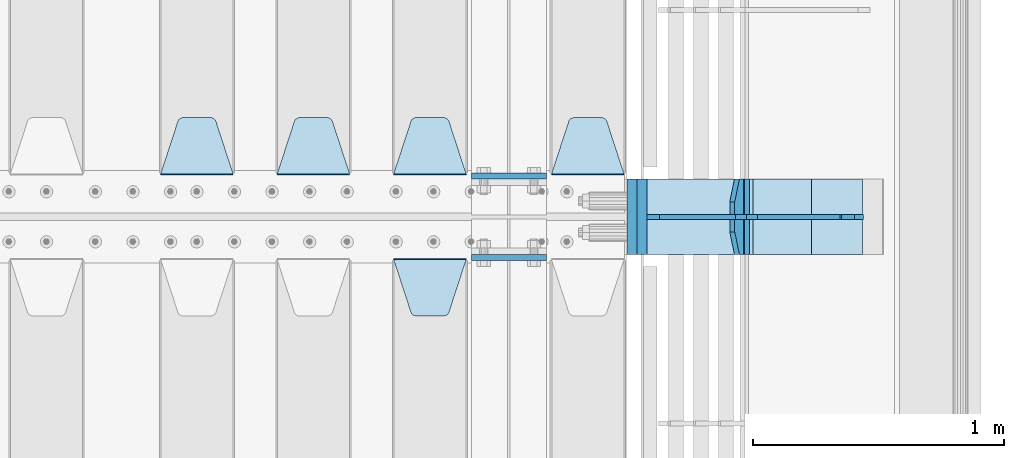
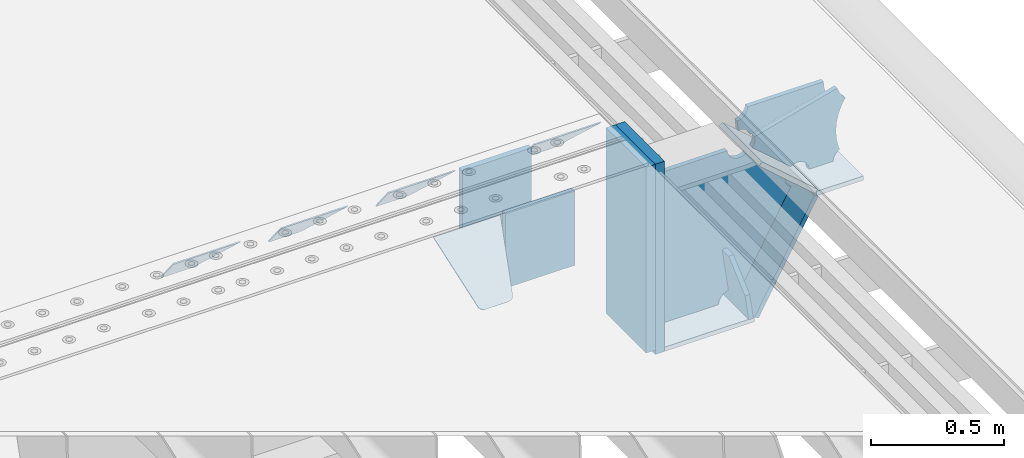
# One storey, part 238 of 257: 17 plates.
"""IFC2X3 building model written with IfcOpenShell, lengths in millimetres."""

from ifc_helpers import new_model, si_unit, frame, origin_with_axes, place, context, subcontext, project, spatial, faceted_brep, material, type_object, element, save


model = new_model("IFC2X3")

# Units and contexts
model_context = context("Model", 3, precision=1e-05, world=origin_with_axes())
body_context = subcontext(model_context, "Body", "Model", "MODEL_VIEW")
ifc_project = project(units=[si_unit("LENGTHUNIT", "METRE", prefix="MILLI"), si_unit("AREAUNIT", "SQUARE_METRE"), si_unit("VOLUMEUNIT", "CUBIC_METRE"), si_unit("MASSUNIT", "GRAM", prefix="KILO"), si_unit("TIMEUNIT", "SECOND"), si_unit("PLANEANGLEUNIT", "RADIAN"), si_unit("SOLIDANGLEUNIT", "STERADIAN"), si_unit("THERMODYNAMICTEMPERATUREUNIT", "DEGREE_CELSIUS"), si_unit("LUMINOUSINTENSITYUNIT", "LUMEN")], contexts=[model_context])

# Site, building, storey
site_placement = place(None, origin_with_axes())
site = spatial("IfcSite", under=ifc_project, at=site_placement, CompositionType="ELEMENT")
building_placement = place(site_placement, origin_with_axes())
building = spatial("IfcBuilding", under=site, at=building_placement, Name="Standard", CompositionType="ELEMENT")
storey_placement = place(building_placement, origin_with_axes())
storey = spatial("IfcBuildingStorey", under=building, at=storey_placement, Name="Undefined", CompositionType="ELEMENT", Elevation=0.0)

# Plates
ifc_material_1 = material(Name="STEEL/S355N")
plate_type_1 = type_object("IfcPlateType", PredefinedType="NOTDEFINED")
for number, where, z_axis, x_axis in (
    (1, (58645.0, 6162.5, -340.000000000044), (0.0, 0.0, 1.0), (1.0, 0.0, 0.0)),
    (2, (58645.0, 5837.5, -340.000000000044), (0.0, 0.0, 1.0), (1.0, 0.0, 0.0)),
):
    element("IfcPlate", number, at=place(storey_placement, frame(where, z_axis=z_axis, x_axis=x_axis)), inside=storey, type_object=plate_type_1, material=ifc_material_1, context=body_context, shape_type="Brep", body=[
        faceted_brep([(0.0, -12.5, 0.0), (0.0, -12.5, 340.0), (0.0, 12.5, 340.0), (0.0, 12.5, 0.0), (300.0, -12.5, 340.0), (300.0, 12.5, 340.0), (300.0, -12.5, 0.0), (300.0, 12.5, 0.0)], [[[0, 1, 2, 3]], [[1, 4, 5, 2]], [[4, 6, 7, 5]], [[6, 0, 3, 7]], [[5, 7, 3, 2]], [[6, 4, 1, 0]]]),
    ])
plate_type_2 = type_object("IfcPlateType", PredefinedType="NOTDEFINED")
plate_1_placement = place(storey_placement, frame((58335.0, 5831.76776695594, -1.767766952965), z_axis=(0.0, -0.707106781186548, -0.707106781186547), x_axis=(1.0, 0.0, 0.0)))
element("IfcPlate", 3, at=plate_1_placement, inside=storey, type_object=plate_type_2, material=ifc_material_1, context=body_context, shape_type="Brep", body=[
    faceted_brep([(0.0, -2.5, 0.0), (69.345504679477, -2.50000000000091, 300.17173142483), (69.345504679477, 2.5, 300.171731424831), (0.0, 2.5, 0.0), (70.927406119954, -2.50000000000091, 304.8974424154), (70.927406119954, 2.5, 304.8974424154), (73.3818627772271, -2.50000000000091, 309.234538108527), (73.3818627772271, 2.49999999999909, 309.234538108527), (76.6187032999587, -2.5, 313.023683126103), (76.6187032999587, 2.5, 313.023683126103), (80.5190132705029, -2.5, 316.125672595372), (80.5190132705029, 2.5, 316.125672595371), (84.9395038596849, -2.5, 318.426546230476), (84.9395038596849, 2.5, 318.426546230477), (89.7177759439219, -2.5, 319.841774983275), (89.7177759439219, 2.5, 319.841774983275), (94.6782862926484, -2.5, 320.319366455079), (94.6782862926484, 2.5, 320.319366455079), (195.321713707352, -2.5, 320.319366455079), (195.321713707352, 2.5, 320.319366455079), (200.282224056078, -2.5, 319.841774983275), (200.282224056078, 2.49999999999909, 319.841774983275), (205.060496140315, -2.5, 318.426546230476), (205.060496140315, 2.49999999999909, 318.426546230475), (209.480986729497, -2.5, 316.125672595371), (209.480986729497, 2.5, 316.125672595371), (213.381296700041, -2.50000000000091, 313.023683126102), (213.381296700041, 2.5, 313.023683126103), (216.618137222766, -2.50000000000091, 309.234538108527), (216.618137222766, 2.5, 309.234538108527), (219.072593880039, -2.5, 304.897442415399), (219.072593880039, 2.5, 304.897442415399), (220.654495320523, -2.50000000000091, 300.17173142483), (220.654495320523, 2.5, 300.171731424831), (290.0, -2.50000000000091, 0.0), (290.0, 2.5, 9.09494701772928e-13)], [[[0, 1, 2, 3]], [[1, 4, 5, 2]], [[4, 6, 7, 5]], [[6, 8, 9, 7]], [[8, 10, 11, 9]], [[10, 12, 13, 11]], [[12, 14, 15, 13]], [[14, 16, 17, 15]], [[16, 18, 19, 17]], [[18, 20, 21, 19]], [[20, 22, 23, 21]], [[22, 24, 25, 23]], [[24, 26, 27, 25]], [[26, 28, 29, 27]], [[28, 30, 31, 29]], [[30, 32, 33, 31]], [[32, 34, 35, 33]], [[34, 0, 3, 35]], [[5, 7, 9, 11, 13, 15, 17, 19, 21, 23, 25, 27, 29, 31, 33, 35, 3, 2]], [[34, 32, 30, 28, 26, 24, 22, 20, 18, 16, 14, 12, 10, 8, 6, 4, 1, 0]]]),
])
plate_2_placement = place(storey_placement, frame((59255.0, 6168.23223304704, -1.76776695296758), z_axis=(0.0, 0.707106781186547, -0.707106781186548), x_axis=(-1.0, 0.0, 0.0)))
element("IfcPlate", 4, at=plate_2_placement, inside=storey, type_object=plate_type_2, material=ifc_material_1, context=body_context, shape_type="Brep", body=[
    faceted_brep([(0.0, -2.5, 0.0), (69.345504679477, -2.50000000000091, 300.17173142483), (69.345504679477, 2.5, 300.171731424831), (0.0, 2.5, 0.0), (70.927406119954, -2.50000000000091, 304.8974424154), (70.927406119954, 2.5, 304.8974424154), (73.3818627772271, -2.50000000000091, 309.234538108527), (73.3818627772271, 2.49999999999909, 309.234538108527), (76.6187032999587, -2.5, 313.023683126103), (76.6187032999587, 2.5, 313.023683126103), (80.5190132705029, -2.5, 316.125672595372), (80.5190132705029, 2.5, 316.125672595371), (84.9395038596849, -2.5, 318.426546230476), (84.9395038596849, 2.5, 318.426546230477), (89.7177759439219, -2.5, 319.841774983275), (89.7177759439219, 2.5, 319.841774983275), (94.6782862926484, -2.5, 320.319366455079), (94.6782862926484, 2.5, 320.319366455079), (195.321713707352, -2.5, 320.319366455079), (195.321713707352, 2.5, 320.319366455079), (200.282224056078, -2.5, 319.841774983275), (200.282224056078, 2.49999999999909, 319.841774983275), (205.060496140315, -2.5, 318.426546230476), (205.060496140315, 2.49999999999909, 318.426546230475), (209.480986729497, -2.5, 316.125672595371), (209.480986729497, 2.5, 316.125672595371), (213.381296700041, -2.50000000000091, 313.023683126102), (213.381296700041, 2.5, 313.023683126103), (216.618137222766, -2.50000000000091, 309.234538108527), (216.618137222766, 2.5, 309.234538108527), (219.072593880039, -2.5, 304.897442415399), (219.072593880039, 2.5, 304.897442415399), (220.654495320523, -2.50000000000091, 300.17173142483), (220.654495320523, 2.5, 300.171731424831), (290.0, -2.50000000000091, 0.0), (290.0, 2.5, 9.09494701772928e-13)], [[[0, 1, 2, 3]], [[1, 4, 5, 2]], [[4, 6, 7, 5]], [[6, 8, 9, 7]], [[8, 10, 11, 9]], [[10, 12, 13, 11]], [[12, 14, 15, 13]], [[14, 16, 17, 15]], [[16, 18, 19, 17]], [[18, 20, 21, 19]], [[20, 22, 23, 21]], [[22, 24, 25, 23]], [[24, 26, 27, 25]], [[26, 28, 29, 27]], [[28, 30, 31, 29]], [[30, 32, 33, 31]], [[32, 34, 35, 33]], [[34, 0, 3, 35]], [[5, 7, 9, 11, 13, 15, 17, 19, 21, 23, 25, 27, 29, 31, 33, 35, 3, 2]], [[34, 32, 30, 28, 26, 24, 22, 20, 18, 16, 14, 12, 10, 8, 6, 4, 1, 0]]]),
])
plate_3_placement = place(storey_placement, frame((58625.0, 6168.23223304704, -1.76776695296758), z_axis=(0.0, 0.707106781186547, -0.707106781186548), x_axis=(-1.0, 0.0, 0.0)))
element("IfcPlate", 5, at=plate_3_placement, inside=storey, type_object=plate_type_2, material=ifc_material_1, context=body_context, shape_type="Brep", body=[
    faceted_brep([(0.0, -2.5, 0.0), (69.345504679477, -2.50000000000091, 300.17173142483), (69.345504679477, 2.5, 300.171731424831), (0.0, 2.5, 0.0), (70.927406119954, -2.50000000000091, 304.8974424154), (70.927406119954, 2.5, 304.8974424154), (73.3818627772271, -2.50000000000091, 309.234538108527), (73.3818627772271, 2.49999999999909, 309.234538108527), (76.6187032999587, -2.5, 313.023683126103), (76.6187032999587, 2.5, 313.023683126103), (80.5190132705029, -2.5, 316.125672595372), (80.5190132705029, 2.5, 316.125672595371), (84.9395038596849, -2.5, 318.426546230476), (84.9395038596849, 2.5, 318.426546230477), (89.7177759439219, -2.5, 319.841774983275), (89.7177759439219, 2.5, 319.841774983275), (94.6782862926484, -2.5, 320.319366455079), (94.6782862926484, 2.5, 320.319366455079), (195.321713707352, -2.5, 320.319366455079), (195.321713707352, 2.5, 320.319366455079), (200.282224056078, -2.5, 319.841774983275), (200.282224056078, 2.49999999999909, 319.841774983275), (205.060496140315, -2.5, 318.426546230476), (205.060496140315, 2.49999999999909, 318.426546230475), (209.480986729497, -2.5, 316.125672595371), (209.480986729497, 2.5, 316.125672595371), (213.381296700041, -2.50000000000091, 313.023683126102), (213.381296700041, 2.5, 313.023683126103), (216.618137222766, -2.50000000000091, 309.234538108527), (216.618137222766, 2.5, 309.234538108527), (219.072593880039, -2.5, 304.897442415399), (219.072593880039, 2.5, 304.897442415399), (220.654495320523, -2.50000000000091, 300.17173142483), (220.654495320523, 2.5, 300.171731424831), (290.0, -2.50000000000091, 0.0), (290.0, 2.5, 9.09494701772928e-13)], [[[0, 1, 2, 3]], [[1, 4, 5, 2]], [[4, 6, 7, 5]], [[6, 8, 9, 7]], [[8, 10, 11, 9]], [[10, 12, 13, 11]], [[12, 14, 15, 13]], [[14, 16, 17, 15]], [[16, 18, 19, 17]], [[18, 20, 21, 19]], [[20, 22, 23, 21]], [[22, 24, 25, 23]], [[24, 26, 27, 25]], [[26, 28, 29, 27]], [[28, 30, 31, 29]], [[30, 32, 33, 31]], [[32, 34, 35, 33]], [[34, 0, 3, 35]], [[5, 7, 9, 11, 13, 15, 17, 19, 21, 23, 25, 27, 29, 31, 33, 35, 3, 2]], [[34, 32, 30, 28, 26, 24, 22, 20, 18, 16, 14, 12, 10, 8, 6, 4, 1, 0]]]),
])
plate_4_placement = place(storey_placement, frame((58160.0, 6168.23223304704, -1.76776695296758), z_axis=(0.0, 0.707106781186547, -0.707106781186548), x_axis=(-1.0, 0.0, 0.0)))
element("IfcPlate", 6, at=plate_4_placement, inside=storey, type_object=plate_type_2, material=ifc_material_1, context=body_context, shape_type="Brep", body=[
    faceted_brep([(0.0, -2.5, 0.0), (69.345504679477, -2.50000000000091, 300.17173142483), (69.345504679477, 2.5, 300.171731424831), (0.0, 2.5, 0.0), (70.927406119954, -2.50000000000091, 304.8974424154), (70.927406119954, 2.5, 304.8974424154), (73.3818627772271, -2.50000000000091, 309.234538108527), (73.3818627772271, 2.49999999999909, 309.234538108527), (76.6187032999587, -2.5, 313.023683126103), (76.6187032999587, 2.5, 313.023683126103), (80.5190132705029, -2.5, 316.125672595372), (80.5190132705029, 2.5, 316.125672595371), (84.9395038596849, -2.5, 318.426546230476), (84.9395038596849, 2.5, 318.426546230477), (89.7177759439219, -2.5, 319.841774983275), (89.7177759439219, 2.5, 319.841774983275), (94.6782862926484, -2.5, 320.319366455079), (94.6782862926484, 2.5, 320.319366455079), (195.321713707352, -2.5, 320.319366455079), (195.321713707352, 2.5, 320.319366455079), (200.282224056078, -2.5, 319.841774983275), (200.282224056078, 2.49999999999909, 319.841774983275), (205.060496140315, -2.5, 318.426546230476), (205.060496140315, 2.49999999999909, 318.426546230475), (209.480986729497, -2.5, 316.125672595371), (209.480986729497, 2.5, 316.125672595371), (213.381296700041, -2.50000000000091, 313.023683126102), (213.381296700041, 2.5, 313.023683126103), (216.618137222766, -2.50000000000091, 309.234538108527), (216.618137222766, 2.5, 309.234538108527), (219.072593880039, -2.5, 304.897442415399), (219.072593880039, 2.5, 304.897442415399), (220.654495320523, -2.50000000000091, 300.17173142483), (220.654495320523, 2.5, 300.171731424831), (290.0, -2.50000000000091, 0.0), (290.0, 2.5, 9.09494701772928e-13)], [[[0, 1, 2, 3]], [[1, 4, 5, 2]], [[4, 6, 7, 5]], [[6, 8, 9, 7]], [[8, 10, 11, 9]], [[10, 12, 13, 11]], [[12, 14, 15, 13]], [[14, 16, 17, 15]], [[16, 18, 19, 17]], [[18, 20, 21, 19]], [[20, 22, 23, 21]], [[22, 24, 25, 23]], [[24, 26, 27, 25]], [[26, 28, 29, 27]], [[28, 30, 31, 29]], [[30, 32, 33, 31]], [[32, 34, 35, 33]], [[34, 0, 3, 35]], [[5, 7, 9, 11, 13, 15, 17, 19, 21, 23, 25, 27, 29, 31, 33, 35, 3, 2]], [[34, 32, 30, 28, 26, 24, 22, 20, 18, 16, 14, 12, 10, 8, 6, 4, 1, 0]]]),
])
plate_5_placement = place(storey_placement, frame((57695.0, 6168.23223304704, -1.76776695296758), z_axis=(0.0, 0.707106781186547, -0.707106781186548), x_axis=(-1.0, 0.0, 0.0)))
element("IfcPlate", 7, at=plate_5_placement, inside=storey, type_object=plate_type_2, material=ifc_material_1, context=body_context, shape_type="Brep", body=[
    faceted_brep([(0.0, -2.5, 0.0), (69.345504679477, -2.50000000000091, 300.17173142483), (69.345504679477, 2.5, 300.171731424831), (0.0, 2.5, 0.0), (70.927406119954, -2.50000000000091, 304.8974424154), (70.927406119954, 2.5, 304.8974424154), (73.3818627772271, -2.50000000000091, 309.234538108527), (73.3818627772271, 2.49999999999909, 309.234538108527), (76.6187032999587, -2.5, 313.023683126103), (76.6187032999587, 2.5, 313.023683126103), (80.5190132705029, -2.5, 316.125672595372), (80.5190132705029, 2.5, 316.125672595371), (84.9395038596849, -2.5, 318.426546230476), (84.9395038596849, 2.5, 318.426546230477), (89.7177759439219, -2.5, 319.841774983275), (89.7177759439219, 2.5, 319.841774983275), (94.6782862926484, -2.5, 320.319366455079), (94.6782862926484, 2.5, 320.319366455079), (195.321713707352, -2.5, 320.319366455079), (195.321713707352, 2.5, 320.319366455079), (200.282224056078, -2.5, 319.841774983275), (200.282224056078, 2.49999999999909, 319.841774983275), (205.060496140315, -2.5, 318.426546230476), (205.060496140315, 2.49999999999909, 318.426546230475), (209.480986729497, -2.5, 316.125672595371), (209.480986729497, 2.5, 316.125672595371), (213.381296700041, -2.50000000000091, 313.023683126102), (213.381296700041, 2.5, 313.023683126103), (216.618137222766, -2.50000000000091, 309.234538108527), (216.618137222766, 2.5, 309.234538108527), (219.072593880039, -2.5, 304.897442415399), (219.072593880039, 2.5, 304.897442415399), (220.654495320523, -2.50000000000091, 300.17173142483), (220.654495320523, 2.5, 300.171731424831), (290.0, -2.50000000000091, 0.0), (290.0, 2.5, 9.09494701772928e-13)], [[[0, 1, 2, 3]], [[1, 4, 5, 2]], [[4, 6, 7, 5]], [[6, 8, 9, 7]], [[8, 10, 11, 9]], [[10, 12, 13, 11]], [[12, 14, 15, 13]], [[14, 16, 17, 15]], [[16, 18, 19, 17]], [[18, 20, 21, 19]], [[20, 22, 23, 21]], [[22, 24, 25, 23]], [[24, 26, 27, 25]], [[26, 28, 29, 27]], [[28, 30, 31, 29]], [[30, 32, 33, 31]], [[32, 34, 35, 33]], [[34, 0, 3, 35]], [[5, 7, 9, 11, 13, 15, 17, 19, 21, 23, 25, 27, 29, 31, 33, 35, 3, 2]], [[34, 32, 30, 28, 26, 24, 22, 20, 18, 16, 14, 12, 10, 8, 6, 4, 1, 0]]]),
])
plate_type_3 = type_object("IfcPlateType", PredefinedType="NOTDEFINED")
plate_6_placement = place(storey_placement, frame((59721.0775331947, 6150.00000000169, -871.412303810021), z_axis=(0.0, -1.0, 0.0), x_axis=(-0.137902988002477, 0.0, 0.990445741017643)))
element("IfcPlate", 8, at=plate_6_placement, inside=storey, type_object=plate_type_3, material=ifc_material_1, context=body_context, shape_type="Brep", body=[
    faceted_brep([(0.0, -10.0, 0.0), (-2.00088834390044e-10, -10.0, 300.0), (-2.00088834390044e-10, 10.0, 300.0), (0.0, 10.0, 0.0), (114.999999999998, -10.0, 300.0), (115.0, 10.0, 300.0), (249.999999999998, -10.0, 210.0), (249.999999999998, 10.0, 210.0), (249.999999999998, -10.0, 90.0), (249.999999999998, 10.0, 90.0), (114.999999999998, -10.0, -1.10503606265411e-10), (115.0, 10.0, -1.10503606265411e-10)], [[[0, 1, 2, 3]], [[1, 4, 5, 2]], [[4, 6, 7, 5]], [[6, 8, 9, 7]], [[8, 10, 11, 9]], [[10, 0, 3, 11]], [[5, 7, 9, 11, 3, 2]], [[10, 8, 6, 4, 1, 0]]]),
])
plate_type_4 = type_object("IfcPlateType", PredefinedType="NOTDEFINED")
plate_7_placement = place(storey_placement, frame((59749.9988298914, 6000.00000000007, -179.999999999866), z_axis=(0.0, 0.0, -1.0), x_axis=(-1.0, 0.0, 0.0)))
element("IfcPlate", 9, at=plate_7_placement, inside=storey, type_object=plate_type_4, material=ifc_material_1, context=body_context, shape_type="Brep", body=[
    faceted_brep([(46.0258547361809, 10.0, 641.078828352491), (73.3015011075258, 10.0, 445.179898435806), (73.3015011075258, -10.0, 445.179898435806), (46.0258547361809, -10.0, 641.078828352491), (53.4925862871751, 10.0, 442.421838675757), (53.4925862871751, -10.0, 442.421838675757), (25.7820501124297, 10.0, 641.4442306713), (25.7820501124297, -10.0, 641.4442306713), (54.6652503111691, 10.0, 642.447174185377), (54.6652503111691, -10.0, 642.447174185377), (68.6036632070463, -10.0, 649.549150281387), (68.6036632070463, 10.0, 649.549150281387), (79.6652503111691, -10.0, 660.610737385511), (79.6652503111691, 10.0, 660.610737385511), (86.7672264071807, -10.0, 674.549150281387), (86.7672264071807, 10.0, 674.549150281387), (89.2144005924201, -10.0, 690.0), (89.2144005924201, 10.0, 690.0), (353.0, -10.0, 690.0), (353.0, 10.0, 690.0), (355.447174185239, -10.0, 674.549150281253), (355.447174185239, 10.0, 674.549150281253), (362.549150281251, -10.0, 660.610737385376), (362.549150281251, 10.0, 660.610737385376), (373.610737385374, -10.0, 649.549150281253), (373.610737385374, 10.0, 649.549150281253), (387.549150281251, -10.0, 642.447174185242), (387.549150281251, 10.0, 642.447174185242), (403.0, -10.0, 640.0), (403.0, 10.0, 640.0), (403.0, -10.0, 50.0), (403.0, 10.0, 50.0), (387.549150281251, -10.0, 47.5528258147577), (387.549150281251, 10.0, 47.5528258147577), (373.610737385374, -10.0, 40.4508497187474), (373.610737385374, 10.0, 40.4508497187474), (362.549150281251, -10.0, 29.3892626146236), (362.549150281251, 10.0, 29.3892626146236), (355.447174185239, -10.0, 15.4508497187474), (355.447174185239, 10.0, 15.4508497187474), (353.0, -10.0, 0.0), (353.0, 10.0, 0.0), (50.0, -10.0, 0.0), (50.0, 10.0, 0.0), (47.0349915316328, -10.0, 16.9620037619133), (47.0349915316328, 10.0, 16.9620037619133), (38.4916171352306, -10.0, 31.9123081320451), (38.4916171352306, 10.0, 31.9123081320451), (25.3831239081483, -10.0, 43.0778019479116), (25.3831239081483, 10.0, 43.0778019479116), (9.26418358741648, -10.0, 49.1342538608113), (9.26418358741648, 10.0, 49.1342538608113), (-7.95349204488593, -10.0, 49.363366622344), (-7.95349204488593, 10.0, 49.363366622344), (-24.2278808265401, -10.0, 43.7379673813837), (-24.2278808265401, 10.0, 43.7379673813837), (-37.6288347353475, -10.0, 32.9252303934259), (-37.6288347353475, 10.0, 32.9252303934259), (-210.371165264653, -10.0, 184.074769606574), (-210.371165264653, 10.0, 184.074769606574), (-202.382363280565, -10.0, 196.529747922069), (-202.382363280565, 10.0, 196.529747922069), (-198.388707244048, -10.0, 210.777489969227), (-198.388707244048, 10.0, 210.777489969227), (-198.73995746443, -10.0, 225.570193077959), (-198.73995746443, 10.0, 225.570193077959), (-203.40535180681, -10.0, 239.612327446012), (-203.40535180681, 10.0, 239.612327446012), (-211.976299808361, -10.0, 251.674097313455), (-211.976299808361, 10.0, 251.674097313455), (-223.702166612966, -10.0, 260.699145216992), (-223.702166612966, 10.0, 260.699145216992), (-9.29783338703419, -10.0, 646.300854783008), (-9.29783338703419, 10.0, 646.300854783008), (6.98069453598146, -10.0, 640.647282345602), (6.98069453598146, 10.0, 640.647282345602), (24.2117663163663, -10.0, 640.855891896051), (24.2117663163663, 10.0, 640.855891896051)], [[[0, 1, 2, 3]], [[4, 5, 2, 1]], [[6, 7, 5, 4]], [[8, 9, 10, 11]], [[11, 10, 12, 13]], [[13, 12, 14, 15]], [[15, 14, 16, 17]], [[18, 19, 17, 16]], [[18, 20, 21, 19]], [[20, 22, 23, 21]], [[22, 24, 25, 23]], [[24, 26, 27, 25]], [[26, 28, 29, 27]], [[28, 30, 31, 29]], [[30, 32, 33, 31]], [[32, 34, 35, 33]], [[34, 36, 37, 35]], [[36, 38, 39, 37]], [[38, 40, 41, 39]], [[40, 42, 43, 41]], [[42, 44, 45, 43]], [[44, 46, 47, 45]], [[46, 48, 49, 47]], [[48, 50, 51, 49]], [[50, 52, 53, 51]], [[52, 54, 55, 53]], [[54, 56, 57, 55]], [[56, 58, 59, 57]], [[58, 60, 61, 59]], [[60, 62, 63, 61]], [[62, 64, 65, 63]], [[64, 66, 67, 65]], [[66, 68, 69, 67]], [[68, 70, 71, 69]], [[70, 72, 73, 71]], [[72, 74, 75, 73]], [[74, 76, 77, 75]], [[1, 0, 8, 11, 13, 15, 17, 19, 21, 23, 25, 27, 29, 31, 33, 35, 37, 39, 41, 43, 45, 47, 49, 51, 53, 55, 57, 59, 61, 63, 65, 67, 69, 71, 73, 75, 77, 6, 4]], [[9, 8, 0, 3]], [[76, 74, 72, 70, 68, 66, 64, 62, 60, 58, 56, 54, 52, 50, 48, 46, 44, 42, 40, 38, 36, 34, 32, 30, 28, 26, 24, 22, 20, 18, 16, 14, 12, 10, 9, 3, 2, 5, 7]], [[77, 76, 7, 6]]]),
])
plate_type_5 = type_object("IfcPlateType", PredefinedType="NOTDEFINED")
plate_8_placement = place(storey_placement, frame((60285.9988298907, 6000.0, -9.99999999999716), z_axis=(0.0, 0.0, -1.0), x_axis=(-1.0, 0.0, 0.0)))
element("IfcPlate", 10, at=plate_8_placement, inside=storey, type_object=plate_type_5, material=ifc_material_1, context=body_context, shape_type="Brep", body=[
    faceted_brep([(164.157641141064, -10.0, 44.1844865875018), (486.71834084086, -10.0, 131.004562768382), (486.71834084086, 10.0, 131.004562768382), (164.157641141064, 10.0, 44.1844865875018), (492.179177700767, -10.0, 118.185717565315), (492.179177700767, 10.0, 118.185717565315), (500.965368826706, -10.0, 107.371542744776), (500.965368826706, 10.0, 107.371542744776), (512.394601349042, -10.0, 99.4018391429503), (512.394601349042, 10.0, 99.4018391429503), (525.579310641864, -10.0, 94.8955133209048), (525.579310641864, 10.0, 94.8955133209048), (539.495606295335, -10.0, 94.2025148824028), (539.495606295335, 10.0, 94.2025148824028), (543.504393704665, -10.0, 49.7974851175972), (543.504393704665, 10.0, 49.7974851175972), (529.167086307512, -10.0, 46.3176139481669), (529.167086307512, 10.0, 46.3176139481669), (516.469507120331, -10.0, 38.8049999196639), (516.469507120331, 10.0, 38.8049999196639), (506.517198234542, -10.0, 27.9137449599276), (506.517198234542, 10.0, 27.9137449599276), (500.17667886756, -10.0, 14.592119649441), (500.17667886756, 10.0, 14.592119649441), (498.0, -10.0, 0.0), (498.0, 10.0, 0.0), (170.0, -10.0, 0.0), (170.0, 10.0, 0.0), (169.632873911985, -10.0, 11.1663820622718), (169.632873911985, 10.0, 11.1663820622718), (168.533081313406, -10.0, 22.2845350637931), (168.533081313406, 10.0, 22.2845350637931), (166.705372351957, -10.0, 33.3064382514178), (166.705372351957, 10.0, 33.3064382514178)], [[[0, 1, 2, 3]], [[1, 4, 5, 2]], [[4, 6, 7, 5]], [[6, 8, 9, 7]], [[8, 10, 11, 9]], [[10, 12, 13, 11]], [[12, 14, 15, 13]], [[14, 16, 17, 15]], [[16, 18, 19, 17]], [[18, 20, 21, 19]], [[20, 22, 23, 21]], [[22, 24, 25, 23]], [[24, 26, 27, 25]], [[26, 28, 29, 27]], [[28, 30, 31, 29]], [[30, 32, 33, 31]], [[32, 0, 3, 33]], [[5, 7, 9, 11, 13, 15, 17, 19, 21, 23, 25, 27, 29, 31, 33, 3, 2]], [[32, 30, 28, 26, 24, 22, 20, 18, 16, 14, 12, 10, 8, 6, 4, 1, 0]]]),
])
plate_type_6 = type_object("IfcPlateType", PredefinedType="NOTDEFINED")
plate_9_placement = place(storey_placement, frame((60290.9988502513, 5999.99999999933, -28.9999913318487), z_axis=(0.260769276985653, 0.0, -0.965401151946889), x_axis=(-0.965401151946889, 0.0, -0.260769276985654)))
element("IfcPlate", 11, at=plate_9_placement, inside=storey, type_object=plate_type_6, material=ifc_material_1, context=body_context, shape_type="Brep", body=[
    faceted_brep([(183.436474692309, 10.0, 275.852500330426), (184.918388609047, 10.0, 264.417843531332), (184.918388609047, -10.0, 264.417843531332), (183.436474692309, -10.0, 275.852500330426), (183.794583267605, 10.0, 224.576469334614), (183.794583267605, -10.0, 224.576469334614), (176.452049775828, 10.0, 185.401410454628), (176.452049775828, -10.0, 185.401410454628), (163.071585676764, 10.0, 147.857286855564), (163.071585676764, -10.0, 147.857286855564), (143.982662403738, 10.0, 112.868559462235), (143.982662403738, -10.0, 112.868559462235), (119.65531260024, 10.0, 81.2967668639885), (119.65531260024, -10.0, 81.2967668639885), (100.960891712741, 10.0, 63.6280409830997), (100.960891712741, -10.0, 63.6280409830997), (194.486836975899, -10.0, 278.751956446691), (207.178624553366, -10.0, 286.65099493752), (207.178624553366, 10.0, 286.65099493752), (194.486836975899, 10.0, 278.751956446691), (216.968013469435, -10.0, 297.948965801401), (216.968013469435, 10.0, 297.948965801401), (222.979925232852, -10.0, 311.635937633771), (222.979925232852, 10.0, 311.635937633771), (323.381647032758, -10.0, 284.515917834988), (323.381647032758, 10.0, 284.515917834988), (321.720617177329, -10.0, 268.853198956864), (321.720617177329, 10.0, 268.853198956864), (325.01434448114, -10.0, 253.450889283185), (325.01434448114, 10.0, 253.450889283185), (332.935986082477, -10.0, 239.837389469556), (332.935986082477, 10.0, 239.837389469556), (344.699462330085, -10.0, 229.36359314694), (344.699462330085, 10.0, 229.36359314694), (359.1374609708, -10.0, 223.068835162203), (359.1374609708, 10.0, 223.068835162203), (374.817271777676, -10.0, 221.577756392893), (374.817271777676, 10.0, 221.577756392893), (390.182952880852, -10.0, 225.03833007813), (390.182952880852, 10.0, 225.03833007813), (512.909060513019, -10.0, 41.5599003357038), (512.909060513019, 10.0, 41.5599003357038), (503.648024844573, -10.0, 33.5643666747728), (503.648024844573, 10.0, 33.5643666747728), (496.6060645697, -10.0, 23.5590612990018), (496.6060645697, 10.0, 23.5590612990018), (492.204839143924, -10.0, 12.1430832451115), (492.204839143924, 10.0, 12.1430832451115), (490.707885742188, -10.0, 3.83806764148176e-10), (490.707885742188, 10.0, 3.83806764148176e-10), (119.999999999993, -10.0, 9.64064383879304e-11), (119.999999999993, 10.0, 9.64064383879304e-11), (117.226254779103, -10.0, 25.6516118492182), (117.226254779103, 10.0, 25.6516118492182), (109.033246825653, -10.0, 50.1173731021008), (109.033246825653, 10.0, 50.1173731021008)], [[[0, 1, 2, 3]], [[4, 5, 2, 1]], [[6, 7, 5, 4]], [[8, 9, 7, 6]], [[10, 11, 9, 8]], [[12, 13, 11, 10]], [[14, 15, 13, 12]], [[16, 17, 18, 19]], [[17, 20, 21, 18]], [[20, 22, 23, 21]], [[22, 24, 25, 23]], [[24, 26, 27, 25]], [[26, 28, 29, 27]], [[28, 30, 31, 29]], [[30, 32, 33, 31]], [[32, 34, 35, 33]], [[34, 36, 37, 35]], [[36, 38, 39, 37]], [[38, 40, 41, 39]], [[40, 42, 43, 41]], [[42, 44, 45, 43]], [[44, 46, 47, 45]], [[46, 48, 49, 47]], [[48, 50, 51, 49]], [[50, 52, 53, 51]], [[52, 54, 55, 53]], [[10, 8, 6, 4, 1, 0, 19, 18, 21, 23, 25, 27, 29, 31, 33, 35, 37, 39, 41, 43, 45, 47, 49, 51, 53, 55, 14, 12]], [[16, 19, 0, 3]], [[54, 52, 50, 48, 46, 44, 42, 40, 38, 36, 34, 32, 30, 28, 26, 24, 22, 20, 17, 16, 3, 2, 5, 7, 9, 11, 13, 15]], [[55, 54, 15, 14]]]),
])
plate_type_7 = type_object("IfcPlateType", PredefinedType="NOTDEFINED")
plate_10_placement = place(storey_placement, frame((59762.2260590443, 6149.99999999933, -177.219372761326), z_axis=(0.752414935148685, 0.0, -0.658689430130164), x_axis=(0.0, -1.0, 0.0)))
element("IfcPlate", 12, at=plate_10_placement, inside=storey, type_object=plate_type_7, material=ifc_material_1, context=body_context, shape_type="Brep", body=[
    faceted_brep([(0.0, -10.0, 0.0), (1.09139364212751e-10, -10.0000000000146, 319.999999999993), (1.09139364212751e-10, 9.99999999999272, 320.0), (0.0, 10.0, 0.0), (300.0, -10.0000000000146, 319.999999999993), (300.0, 9.99999999999272, 320.0), (300.0, -10.0000000000073, 5.82076609134674e-11), (300.0, 9.99999999999272, 5.82076609134674e-11)], [[[0, 1, 2, 3]], [[1, 4, 5, 2]], [[4, 6, 7, 5]], [[6, 0, 3, 7]], [[5, 7, 3, 2]], [[6, 4, 1, 0]]]),
])
plate_11_placement = place(storey_placement, frame((60003.0007288109, 6150.00000000007, -408.004820491625), z_axis=(-0.484064236150485, 0.0, -0.875032465272031), x_axis=(0.0, -1.0, 0.0)))
element("IfcPlate", 13, at=plate_11_placement, inside=storey, type_object=plate_type_7, material=ifc_material_1, context=body_context, shape_type="Brep", body=[
    faceted_brep([(0.0, -10.0, 0.0), (3.86515239370056e-07, -10.0, 533.528442382816), (3.86515239370056e-07, 10.0, 533.528442382813), (0.0, 10.0, 0.0), (300.003295898438, -10.0, 533.549133300781), (300.003295898438, 10.0, 533.549133300785), (300.0, -10.0000000000073, 5.82076609134674e-11), (300.0, 9.99999999999272, 5.82076609134674e-11)], [[[0, 1, 2, 3]], [[1, 4, 5, 2]], [[4, 6, 7, 5]], [[6, 0, 3, 7]], [[5, 7, 3, 2]], [[6, 4, 1, 0]]]),
])
plate_12_placement = place(storey_placement, frame((59346.9988298914, 6150.00000000007, -879.999999999866), z_axis=(0.0, -1.0, 0.0), x_axis=(1.0, 0.0, 0.0)))
element("IfcPlate", 14, at=plate_12_placement, inside=storey, type_object=plate_type_7, material=ifc_material_1, context=body_context, shape_type="Brep", body=[
    faceted_brep([(0.0, -10.0, 0.0), (-2.00088834390044e-10, -10.0, 300.0), (-2.00088834390044e-10, 10.0, 300.0), (0.0, 10.0, 0.0), (389.0, -10.0, 300.0), (389.0, 10.0, 300.0), (389.0, -10.0, 0.0), (389.0, 10.0, 0.0)], [[[0, 1, 2, 3]], [[1, 4, 5, 2]], [[4, 6, 7, 5]], [[6, 0, 3, 7]], [[5, 7, 3, 2]], [[6, 4, 1, 0]]]),
])
plate_type_8 = type_object("IfcPlateType", PredefinedType="NOTDEFINED")
plate_13_placement = place(storey_placement, frame((60206.9988298914, 6149.99999999933, -397.999999999763), z_axis=(-1.0, 0.0, 0.0), x_axis=(0.0, -1.0, 0.0)))
element("IfcPlate", 15, at=plate_13_placement, inside=storey, type_object=plate_type_8, material=ifc_material_1, context=body_context, shape_type="Brep", body=[
    faceted_brep([(0.0, -10.0, 0.0), (4.63842297904193e-10, -10.0, 204.0), (4.63842297904193e-10, 10.0, 204.0), (0.0, 10.0, 0.0), (300.0, -10.0, 204.0), (300.0, 10.0, 204.0), (300.0, -10.0000000000073, 5.82076609134674e-11), (300.0, 9.99999999999272, 5.82076609134674e-11)], [[[0, 1, 2, 3]], [[1, 4, 5, 2]], [[4, 6, 7, 5]], [[6, 0, 3, 7]], [[5, 7, 3, 2]], [[6, 4, 1, 0]]]),
])
ifc_material_2 = material()
plate_type_9 = type_object("IfcPlateType", PredefinedType="NOTDEFINED")
plate_14_placement = place(storey_placement, frame((59326.9988298907, 6150.0, -889.999999999995), z_axis=(0.0, 0.0, 1.0), x_axis=(0.0, -1.0, 0.0)))
element("IfcPlate", 16, at=plate_14_placement, inside=storey, type_object=plate_type_9, material=ifc_material_2, context=body_context, shape_type="Brep", body=[
    faceted_brep([(0.0, -20.0, 0.0), (0.0, -20.0, 870.0), (0.0, 20.0, 870.0), (0.0, 20.0, 0.0), (300.0, -20.0, 870.0), (300.0, 20.0, 870.0), (300.0, -20.0, -1.81898940354586e-12), (300.0, 20.0, -1.81898940354586e-12)], [[[0, 1, 2, 3]], [[1, 4, 5, 2]], [[4, 6, 7, 5]], [[6, 0, 3, 7]], [[5, 7, 3, 2]], [[6, 4, 1, 0]]]),
])
plate_15_placement = place(storey_placement, frame((59287.0, 6150.0, -870.0), z_axis=(0.0, 0.0, 1.0), x_axis=(0.0, -1.0, 0.0)))
element("IfcPlate", 17, at=plate_15_placement, inside=storey, type_object=plate_type_9, material=ifc_material_2, context=body_context, shape_type="Brep", body=[
    faceted_brep([(0.0, -20.0, 0.0), (0.0, -20.0, 850.0), (0.0, 20.0, 850.0), (0.0, 20.0, 0.0), (300.0, -20.0, 850.0), (300.0, 20.0, 850.0), (300.0, -20.0, -1.81898940354586e-12), (300.0, 20.0, -1.81898940354586e-12)], [[[0, 1, 2, 3]], [[1, 4, 5, 2]], [[4, 6, 7, 5]], [[6, 0, 3, 7]], [[5, 7, 3, 2]], [[6, 4, 1, 0]]]),
])

save(model, "model.ifc")
